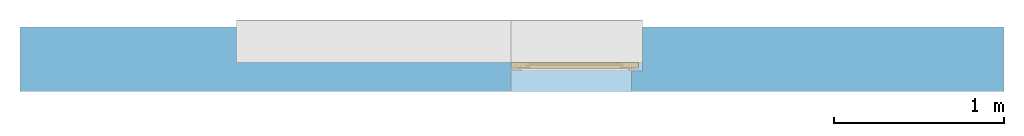
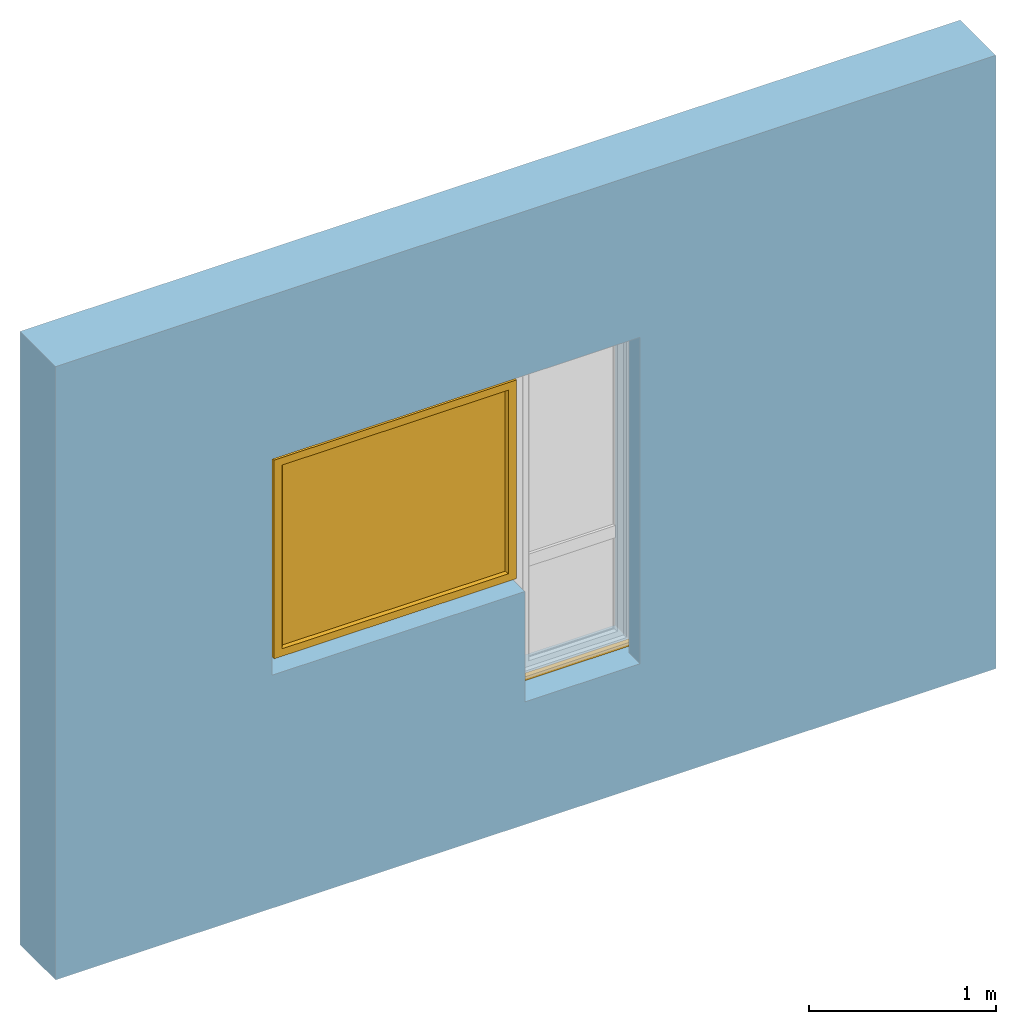
# One storey, part 2 of 4: 1 window, 1 opening, plus 1 element that does not belong to this part.
"""IFC2X3 building model written with IfcOpenShell, lengths in millimetres."""

from ifc_helpers import new_model, entity, si_unit, converted_unit, derived_unit, direction, frame, frame_2d, origin, place, context, subcontext, project, spatial, rectangle, extrude, faceted_brep, source, transform, mapped, material, material_list, layer, layer_set, layer_usage, type_object, type_shapes, element, fill, save


model = new_model("IFC2X3")

# Units and contexts
model_context = context("Model", 3, precision=0.01, world=origin(), true_north=direction((6.12303176911189e-17, 1.0)))
context_of_model = context(None, 3, precision=0.01, world=origin(), true_north=direction((6.12303176911189e-17, 1.0)))
body_context = subcontext(model_context, "Body", "Model", "MODEL_VIEW")
ifc_project = project(units=[si_unit("LENGTHUNIT", "METRE", prefix="MILLI"), si_unit("AREAUNIT", "SQUARE_METRE"), si_unit("VOLUMEUNIT", "CUBIC_METRE"), converted_unit("PLANEANGLEUNIT", "DEGREE", entity("IfcRatioMeasure", 0.0174532925199433), si_unit("PLANEANGLEUNIT", "RADIAN"), dimensions=[0, 0, 0, 0, 0, 0, 0]), si_unit("MASSUNIT", "GRAM", prefix="KILO"), si_unit("TIMEUNIT", "SECOND"), si_unit("FREQUENCYUNIT", "HERTZ"), si_unit("THERMODYNAMICTEMPERATUREUNIT", "DEGREE_CELSIUS"), derived_unit("THERMALTRANSMITTANCEUNIT", [(si_unit("MASSUNIT", "GRAM", prefix="KILO"), 1), (si_unit("THERMODYNAMICTEMPERATUREUNIT", "KELVIN"), -1), (si_unit("TIMEUNIT", "SECOND"), -3)]), derived_unit("VOLUMETRICFLOWRATEUNIT", [(si_unit("LENGTHUNIT", "METRE"), 3), (si_unit("TIMEUNIT", "SECOND"), -1)]), si_unit("ELECTRICCURRENTUNIT", "AMPERE"), si_unit("ELECTRICVOLTAGEUNIT", "VOLT"), si_unit("POWERUNIT", "WATT"), si_unit("FORCEUNIT", "NEWTON", prefix="KILO"), si_unit("ILLUMINANCEUNIT", "LUX"), si_unit("LUMINOUSFLUXUNIT", "LUMEN"), si_unit("LUMINOUSINTENSITYUNIT", "CANDELA"), si_unit("PRESSUREUNIT", "PASCAL")], contexts=[model_context, context_of_model])

# Site, building, storey
site_placement = place(None, origin())
site = spatial("IfcSite", under=ifc_project, at=site_placement, CompositionType="ELEMENT")
building_placement = place(site_placement, origin())
building = spatial("IfcBuilding", under=site, at=building_placement, CompositionType="ELEMENT")
storey_placement = place(building_placement, origin())
storey = spatial("IfcBuildingStorey", under=building, at=storey_placement, CompositionType="ELEMENT", Elevation=0.0)

# Wall, opening, window
ifc_material_1 = material()
ifc_layer = layer(ifc_material_1, 380.0)
ifc_layer_set = layer_set([ifc_layer])
ifc_layer_usage = layer_usage(ifc_layer_set, "AXIS2", "NEGATIVE", 190.0)
wall_type = type_object("IfcWallType", PredefinedType="STANDARD", material=ifc_layer_set)
wall_placement = place(storey_placement, frame((-18279.8270290102, 12543.5585138251, 0.0)))
wall = element("IfcWallStandardCase", 1, at=wall_placement, inside=storey, type_object=wall_type, material=ifc_layer_usage, context=body_context, shape_type="SweptSolid", body=[
    extrude(rectangle(XDim=5800.0, YDim=380.0, at=frame_2d((2900.0, 0.0), x_axis=(-1.0, 0.0))), origin(), (0.0, 0.0, 1.0), 4000.0),
])
opening_placement = place(wall_placement, frame((1270.4425727851, -570.0, 800.0)))
opening = element("IfcOpeningElement", 2, at=opening_placement, cuts=wall, ObjectType="Opening", context=body_context, shape_type="Brep", body=[
    faceted_brep([(2400.0, 1490.0, 2195.0), (2400.0, 1490.0, 0.0), (1625.0, 1490.0, 0.0), (1625.0, 1490.0, 720.0), (0.0, 1490.0, 720.0), (0.0, 1490.0, 2170.0), (0.0, 1490.0, 2195.0), (1330.0, 1490.0, 2195.0), (2400.0, 500.0, 2195.0), (1330.0, 500.0, 2195.0), (0.0, 500.0, 2195.0), (0.0, 500.0, 2170.0), (0.0, 500.0, 720.0), (65.0, 500.0, 720.0), (65.0, 500.0, 2130.0), (1715.0, 500.0, 2130.0), (2335.0, 500.0, 2130.0), (2335.0, 500.0, 0.0), (2400.0, 500.0, 0.0), (1625.0, 0.0, 0.0), (1625.0, 0.0, 720.0), (2335.0, 0.0, 0.0), (65.0, 0.0, 720.0), (2335.0, 0.0, 2130.0), (1715.0, 0.0, 2130.0), (65.0, 0.0, 2130.0)], [[[0, 1, 2, 3, 4, 5, 6, 7]], [[8, 9, 10, 11, 12, 13, 14, 15, 16, 17, 18]], [[7, 9, 8, 0]], [[2, 19, 20, 3]], [[1, 18, 17, 21, 19, 2]], [[0, 8, 18, 1]], [[6, 10, 9, 7]], [[5, 11, 10, 6]], [[4, 12, 11, 5]], [[20, 22, 13, 12, 4, 3]], [[23, 24, 25, 22, 20, 19, 21]], [[23, 16, 15, 24]], [[21, 17, 16, 23]], [[24, 15, 14, 25]], [[25, 14, 13, 22]]]),
])
ifc_material_2 = material()
ifc_material_3 = material()
ifc_material_4 = material()
ifc_material_5 = material()
ifc_material_list_1 = material_list([ifc_material_2, ifc_material_3, ifc_material_4, ifc_material_5])
ifc_material_list_2 = material_list([ifc_material_2, ifc_material_3, ifc_material_4, ifc_material_5])
window_style = type_object("IfcWindowStyle", ConstructionType="NOTDEFINED", OperationType="NOTDEFINED", ParameterTakesPrecedence=False, Sizeable=False, material=ifc_material_list_2)
shared_shape = source(origin(), body_context, "Body", "Brep", [
    faceted_brep([(2316.0, 1030.0, 1488.0), (2316.0, 1030.0, 1452.0), (2316.0, 1038.0, 1452.0), (2316.0, 1038.0, 1488.0), (2315.15676402479, 1038.0, 1492.78534851355), (2315.57778161414, 1030.0, 1490.39432433825), (2310.86155337324, 1030.0, 1498.56228263264), (2309.00202746121, 1038.0, 1500.12318487169), (2308.99898619598, 1030.0, 1500.12494091652), (2293.13844662676, 1038.0, 1498.56228263264), (2294.99797253879, 1030.0, 1500.12318487169), (2295.00101380402, 1038.0, 1500.12494091652), (2312.7263777273, 1038.0, 1496.99693396951), (2312.7241205505, 1030.0, 1496.99962434876), (2313.93984188939, 1030.0, 1494.89413651262), (2304.432995843, 1038.0, 1501.78696961731), (2304.42953736881, 1030.0, 1501.78757948932), (2306.7142617824, 1030.0, 1500.95626020292), (2310.86420259425, 1038.0, 1498.5600594206), (2315.15556322829, 1030.0, 1492.78864867648), (2313.94157087605, 1038.0, 1494.89114124153), (2306.7175116521, 1038.0, 1500.9550772445), (2299.57046263119, 1038.0, 1501.78757948932), (2299.567004157, 1030.0, 1501.78696961731), (2301.9982707629, 1030.0, 1501.78727455331), (2297.2824883479, 1030.0, 1500.9550772445), (2297.2857382176, 1038.0, 1500.95626020292), (2290.05842912395, 1030.0, 1494.89114124153), (2288.84443677171, 1038.0, 1492.78864867648), (2288.84323597521, 1030.0, 1492.78534851355), (2291.2758794495, 1038.0, 1496.99962434876), (2291.2736222727, 1030.0, 1496.99693396951), (2293.13579740575, 1030.0, 1498.5600594206), (2302.0017292371, 1038.0, 1501.78727455331), (2288.0, 1030.0, 1488.0), (2288.42221838586, 1038.0, 1490.39432433825), (2288.0, 1038.0, 1488.0), (2290.06015811061, 1038.0, 1494.89413651262), (2288.0, 1030.0, 1452.0), (2288.0, 1038.0, 1452.0), (2288.84323597521, 1030.0, 1447.21465148647), (2288.84323597521, 1038.0, 1447.21465148647), (2294.99797253879, 1030.0, 1439.87681512833), (2293.13579740575, 1030.0, 1441.43994057942), (2291.2736222727, 1030.0, 1443.00306603051), (2291.2736222727, 1038.0, 1443.00306603051), (2293.13579740575, 1038.0, 1441.43994057942), (2294.99797253879, 1038.0, 1439.87681512833), (2315.57778161414, 1030.0, 1449.60567566177), (2315.15556322829, 1030.0, 1447.21135132354), (2315.15556322829, 1038.0, 1447.21135132354), (2315.56908263974, 1038.0, 1449.55634534639), (2290.05842912395, 1038.0, 1445.10885875849), (2290.05842912395, 1030.0, 1445.10885875849), (2297.2824883479, 1038.0, 1439.04492275552), (2299.567004157, 1038.0, 1438.21303038271), (2299.567004157, 1030.0, 1438.21303038271), (2297.2824883479, 1030.0, 1439.04492275552), (2304.42953736881, 1030.0, 1438.21242051071), (2301.9982707629, 1030.0, 1438.21272544671), (2301.9982707629, 1038.0, 1438.21272544671), (2304.42953736881, 1038.0, 1438.21242051071), (2306.7142617824, 1038.0, 1439.04373979711), (2308.99898619598, 1038.0, 1439.87505908351), (2308.99898619598, 1030.0, 1439.87505908351), (2306.7142617824, 1030.0, 1439.04373979711), (2310.86155337324, 1038.0, 1441.43771736738), (2312.7241205505, 1038.0, 1443.00037565126), (2312.7241205505, 1030.0, 1443.00037565126), (2310.86155337324, 1030.0, 1441.43771736738), (2313.93984188939, 1038.0, 1445.1058634874), (2313.93984188939, 1030.0, 1445.1058634874), (2292.63603896932, 1028.0, 1494.3639610307), (2291.75735931288, 1028.0, 1492.24264068714), (2290.87867965644, 1028.0, 1490.12132034358), (2290.0, 1028.0, 1488.0), (2290.0, 1028.0, 1452.0), (2290.87867965644, 1028.0, 1449.87867965644), (2291.75735931288, 1028.0, 1447.75735931288), (2292.63603896932, 1028.0, 1445.63603896932), (2293.51471862576, 1028.0, 1443.51471862576), (2295.63603896932, 1028.0, 1442.63603896932), (2297.75735931288, 1028.0, 1441.75735931288), (2299.87867965644, 1028.0, 1440.87867965644), (2302.0, 1028.0, 1440.0), (2304.12132034356, 1028.0, 1440.87867965644), (2306.24264068712, 1028.0, 1441.75735931288), (2308.36396103068, 1028.0, 1442.63603896932), (2310.48528137424, 1028.0, 1443.51471862576), (2311.36396103068, 1028.0, 1445.63603896932), (2312.24264068712, 1028.0, 1447.75735931288), (2313.12132034356, 1028.0, 1449.87867965644), (2314.0, 1028.0, 1452.0), (2314.0, 1028.0, 1488.0), (2313.12132034356, 1028.0, 1490.12132034358), (2312.24264068712, 1028.0, 1492.24264068714), (2311.36396103068, 1028.0, 1494.3639610307), (2310.48528137424, 1028.0, 1496.48528137426), (2308.36396103068, 1028.0, 1497.3639610307), (2306.24264068712, 1028.0, 1498.24264068714), (2304.12132034356, 1028.0, 1499.12132034358), (2302.0, 1028.0, 1500.0), (2299.87867965644, 1028.0, 1499.12132034358), (2297.75735931288, 1028.0, 1498.24264068714), (2295.63603896932, 1028.0, 1497.3639610307), (2293.51471862576, 1028.0, 1496.48528137426), (2290.0, 1040.0, 1488.0), (2290.87867965644, 1040.0, 1490.12132034358), (2291.75735931288, 1040.0, 1492.24264068714), (2292.63603896932, 1040.0, 1494.3639610307), (2293.51471862576, 1040.0, 1496.48528137426), (2295.63603896932, 1040.0, 1497.3639610307), (2297.75735931288, 1040.0, 1498.24264068714), (2299.87867965644, 1040.0, 1499.12132034358), (2302.0, 1040.0, 1500.0), (2304.12132034356, 1040.0, 1499.12132034358), (2306.24264068712, 1040.0, 1498.24264068714), (2308.36396103068, 1040.0, 1497.3639610307), (2310.48528137424, 1040.0, 1496.48528137426), (2311.36396103068, 1040.0, 1494.3639610307), (2312.24264068712, 1040.0, 1492.24264068714), (2313.12132034356, 1040.0, 1490.12132034358), (2314.0, 1040.0, 1488.0), (2314.0, 1040.0, 1452.0), (2313.12132034356, 1040.0, 1449.87867965644), (2312.24264068712, 1040.0, 1447.75735931288), (2311.36396103068, 1040.0, 1445.63603896932), (2310.48528137424, 1040.0, 1443.51471862576), (2308.36396103068, 1040.0, 1442.63603896932), (2306.24264068712, 1040.0, 1441.75735931288), (2304.12132034356, 1040.0, 1440.87867965644), (2302.0, 1040.0, 1440.0), (2299.87867965644, 1040.0, 1440.87867965644), (2297.75735931288, 1040.0, 1441.75735931288), (2295.63603896932, 1040.0, 1442.63603896932), (2293.51471862576, 1040.0, 1443.51471862576), (2292.63603896932, 1040.0, 1445.63603896932), (2291.75735931288, 1040.0, 1447.75735931288), (2290.87867965644, 1040.0, 1449.87867965644), (2290.0, 1040.0, 1452.0)], [[[0, 1, 2, 3]], [[4, 5, 3]], [[6, 7, 8]], [[9, 10, 11]], [[12, 13, 14]], [[15, 16, 17]], [[7, 6, 18]], [[5, 0, 3]], [[18, 6, 13]], [[14, 19, 20]], [[4, 19, 5]], [[15, 17, 21]], [[8, 21, 17]], [[12, 14, 20]], [[22, 23, 24]], [[25, 11, 10]], [[26, 23, 22]], [[27, 28, 29]], [[21, 8, 7]], [[20, 19, 4]], [[30, 31, 32]], [[33, 16, 15]], [[34, 35, 36]], [[11, 25, 26]], [[23, 26, 25]], [[37, 27, 31]], [[32, 10, 9]], [[29, 28, 35]], [[30, 32, 9]], [[34, 29, 35]], [[28, 27, 37]], [[18, 13, 12]], [[33, 24, 16]], [[37, 31, 30]], [[22, 24, 33]], [[38, 34, 36, 39]], [[40, 38, 39, 41]], [[42, 43, 44, 45, 46, 47]], [[2, 1, 48, 49, 50, 51]], [[41, 52, 45, 44, 53, 40]], [[47, 54, 55, 56, 57, 42]], [[58, 59, 56, 55, 60, 61]], [[61, 62, 63, 64, 65, 58]], [[66, 67, 68, 69, 64, 63]], [[67, 70, 50, 49, 71, 68]], [[72, 73, 74, 75, 76, 77, 78, 79, 80, 81, 82, 83, 84, 85, 86, 87, 88, 89, 90, 91, 92, 93, 94, 95, 96, 97, 98, 99, 100, 101, 102, 103, 104, 105]], [[92, 48, 1]], [[48, 92, 91]], [[71, 49, 90]], [[44, 79, 53]], [[90, 49, 91]], [[78, 40, 53]], [[88, 68, 89]], [[88, 69, 68]], [[69, 87, 64]], [[89, 68, 71]], [[82, 57, 83]], [[91, 49, 48]], [[65, 85, 58]], [[82, 42, 57]], [[56, 84, 83]], [[65, 64, 86]], [[56, 83, 57]], [[76, 38, 77]], [[58, 84, 56, 59]], [[80, 44, 43]], [[85, 65, 86]], [[40, 77, 38]], [[82, 81, 42]], [[40, 78, 77]], [[43, 81, 80]], [[71, 90, 89]], [[87, 69, 88]], [[79, 44, 80]], [[79, 78, 53]], [[87, 86, 64]], [[85, 84, 58]], [[43, 42, 81]], [[92, 1, 0, 93]], [[72, 31, 27]], [[34, 74, 29]], [[27, 29, 73]], [[13, 96, 14]], [[74, 73, 29]], [[95, 19, 14]], [[104, 32, 105]], [[105, 32, 31]], [[32, 104, 10]], [[105, 31, 72]], [[99, 17, 100]], [[74, 34, 75]], [[25, 102, 23]], [[99, 8, 17]], [[16, 101, 100]], [[25, 10, 103]], [[16, 100, 17]], [[5, 93, 0]], [[99, 98, 8]], [[97, 13, 6]], [[93, 5, 94]], [[102, 25, 103]], [[94, 5, 19]], [[24, 23, 101, 16]], [[27, 73, 72]], [[96, 13, 97]], [[6, 98, 97]], [[96, 95, 14]], [[104, 103, 10]], [[102, 101, 23]], [[6, 8, 98]], [[94, 19, 95]], [[75, 34, 38, 76]], [[106, 107, 108, 109, 110, 111, 112, 113, 114, 115, 116, 117, 118, 119, 120, 121, 122, 123, 124, 125, 126, 127, 128, 129, 130, 131, 132, 133, 134, 135, 136, 137, 138, 139]], [[136, 45, 52]], [[39, 138, 41]], [[52, 41, 137]], [[67, 126, 70]], [[138, 137, 41]], [[125, 50, 70]], [[134, 46, 135]], [[135, 46, 45]], [[46, 134, 47]], [[135, 45, 136]], [[129, 62, 130]], [[138, 39, 139]], [[54, 132, 55]], [[129, 63, 62]], [[61, 131, 130]], [[54, 47, 133]], [[61, 130, 62]], [[51, 123, 2]], [[129, 128, 63]], [[127, 67, 66]], [[123, 51, 124]], [[132, 54, 133]], [[124, 51, 50]], [[60, 55, 131, 61]], [[52, 137, 136]], [[126, 67, 127]], [[66, 128, 127]], [[126, 125, 70]], [[134, 133, 47]], [[132, 131, 55]], [[66, 63, 128]], [[124, 50, 125]], [[122, 3, 2, 123]], [[119, 12, 20]], [[3, 121, 4]], [[20, 4, 120]], [[30, 109, 37]], [[121, 120, 4]], [[108, 28, 37]], [[117, 18, 118]], [[118, 18, 12]], [[18, 117, 7]], [[118, 12, 119]], [[112, 26, 113]], [[121, 3, 122]], [[21, 115, 15]], [[112, 11, 26]], [[22, 114, 113]], [[21, 7, 116]], [[22, 113, 26]], [[35, 106, 36]], [[112, 111, 11]], [[110, 30, 9]], [[106, 35, 107]], [[115, 21, 116]], [[107, 35, 28]], [[33, 15, 114, 22]], [[20, 120, 119]], [[109, 30, 110]], [[9, 111, 110]], [[109, 108, 37]], [[117, 116, 7]], [[115, 114, 15]], [[9, 11, 111]], [[107, 28, 108]], [[139, 39, 36, 106]]]),
    faceted_brep([(2296.70849737789, 979.723224744612, 1410.52114796617), (2307.29150262214, 979.723224744611, 1410.52114796617), (2307.29150262214, 984.162114765246, 1452.66882878318), (2296.70849737789, 984.162114765247, 1452.66882878318), (2309.48331477356, 988.551651869357, 1410.52114796617), (2309.48331477356, 992.796844327483, 1450.82965209673), (2302.0, 993.723224744612, 1410.52114796617), (2302.0, 997.854951797618, 1449.75228733741), (2294.51668522647, 988.551651869359, 1410.52114796617), (2294.51668522647, 992.796844327484, 1450.82965209673), (2296.70849737789, 984.162114765246, 1368.37346714915), (2307.29150262214, 984.162114765245, 1368.37346714915), (2309.48331477356, 992.796844327482, 1370.2126438356), (2302.0, 997.854951797618, 1371.29000859492), (2294.51668522647, 992.796844327484, 1370.2126438356)], [[[0, 1, 2, 3]], [[1, 4, 5, 2]], [[4, 6, 7, 5]], [[6, 8, 9, 7]], [[8, 0, 3, 9]], [[10, 11, 1, 0]], [[11, 12, 4, 1]], [[12, 13, 6, 4]], [[13, 14, 8, 6]], [[14, 10, 0, 8]], [[3, 2, 5, 7, 9]], [[14, 13, 12, 11, 10]]]),
    faceted_brep([(2292.05108068303, 1028.0, 1470.94591729901), (2292.6116955587, 1028.0, 1473.43924096907), (2293.78926206305, 1028.0, 1475.70333478471), (2295.50517385398, 1028.0, 1477.59726390535), (2297.64110105648, 1028.0, 1479.0), (2302.0, 1028.0, 1479.0), (2306.35889894356, 1028.0, 1479.0), (2308.49482614605, 1028.0, 1477.59726390535), (2310.21073793698, 1028.0, 1475.70333478471), (2311.38830444134, 1028.0, 1473.43924096907), (2311.948919317, 1028.0, 1470.94591729901), (2311.86909546584, 1028.0, 1468.3919203214), (2311.13720137139, 1028.0, 1465.94604186494), (2309.80945551189, 1028.0, 1463.7614130413), (2307.97703479258, 1028.0, 1461.98307257928), (2305.74800577773, 1028.0, 1460.73512735946), (2303.27629940962, 1028.0, 1460.08403873227), (2300.72370059042, 1028.0, 1460.08403873227), (2298.25199422231, 1028.0, 1460.73512735946), (2296.02296520745, 1028.0, 1461.98307257928), (2294.19054448814, 1028.0, 1463.7614130413), (2292.86279862864, 1028.0, 1465.94604186494), (2292.13090453419, 1028.0, 1468.3919203214), (2295.36991581395, 985.428800128993, 1451.81582813483), (2294.45534262368, 986.933218860171, 1450.80273507336), (2294.03032959918, 988.579532805234, 1449.69408812541), (2294.11827066873, 990.263398076606, 1448.56015367782), (2294.7119819839, 991.873838872343, 1447.47566412563), (2295.77997796969, 993.307181915701, 1446.51043425854), (2297.2448781787, 994.474223513816, 1445.72453488026), (2299.01896983583, 995.293497882215, 1445.17282599704), (2300.98499562504, 995.719017712972, 1444.88627599662), (2303.01500437499, 995.719017712972, 1444.88627599662), (2304.9810301642, 995.293497882215, 1445.17282599704), (2306.75512182133, 994.474223513816, 1445.72453488026), (2308.22002203034, 993.307181915701, 1446.51043425854), (2309.28801801613, 991.873838872343, 1447.47566412563), (2309.88172933131, 990.263398076606, 1448.56015367782), (2309.96967040085, 988.579532805233, 1449.69408812541), (2309.54465737635, 986.933218860171, 1450.80273507336), (2308.63008418608, 985.428800128993, 1451.81582813483), (2307.29150262214, 984.16133280708, 1452.6693553629), (2303.79310555172, 984.16133280708, 1452.6693553629), (2300.2508014648, 984.16133280708, 1452.6693553629), (2296.70849737789, 984.16133280708, 1452.6693553629), (2304.52949888047, 998.583676958967, 1468.53479166182), (2302.0, 1001.40749625602, 1470.46960324719), (2302.02195286218, 991.069044221466, 1461.86725150298), (2307.17259060864, 988.432156174774, 1457.7486255059), (2304.75377578685, 990.997000236885, 1461.79007956711), (2299.62092495289, 997.432874221653, 1467.66721198755), (2299.76284265702, 1005.82183838693, 1473.00337884316), (2297.01936527075, 995.326410429836, 1465.9479296637), (2299.15805318919, 990.078190113558, 1460.7785343575), (2300.96832520456, 1014.05926083179, 1476.41174131507), (2297.33023316361, 1010.43252257805, 1475.10298096761), (2304.09205911857, 1018.08338546997, 1477.54270145077), (2306.98063472928, 995.326410429835, 1465.9479296637), (2306.66976683642, 1010.43252257805, 1475.10298096761), (2310.33445262988, 995.924208850621, 1455.92276589621), (2310.86792617061, 1008.48015750033, 1468.07942490609), (2311.45909914595, 1017.75942703354, 1470.08550854293), (2305.91403231325, 999.739374449793, 1450.68801313961), (2307.61971635533, 1004.55574499169, 1455.78506579303), (2295.02520991073, 1001.74472638059, 1455.70424775686), (2292.98228348089, 1009.89849311155, 1468.22389640409), (2295.18111717899, 1012.97756270999, 1460.9239931882), (2308.84403415027, 1015.58259477426, 1461.67364545901), (2310.7354074063, 1001.45564404689, 1462.17506192797), (2292.69314957983, 1018.88103613784, 1466.84627828438), (2299.47019846674, 1020.31531244094, 1459.97313305256)], [[[0, 1, 2, 3, 4, 5, 6, 7, 8, 9, 10, 11, 12, 13, 14, 15, 16, 17, 18, 19, 20, 21, 22]], [[23, 24, 25, 26, 27, 28, 29, 30, 31, 32, 33, 34, 35, 36, 37, 38, 39, 40, 41, 42, 43, 44]], [[45, 46, 47]], [[42, 41, 48]], [[49, 45, 47]], [[50, 46, 51]], [[50, 51, 52]], [[43, 47, 53]], [[53, 50, 52]], [[54, 4, 55]], [[44, 43, 53]], [[56, 6, 5]], [[48, 49, 42]], [[42, 47, 43]], [[49, 48, 57]], [[5, 54, 56]], [[49, 57, 45]], [[42, 49, 47]], [[57, 58, 45]], [[58, 46, 45]], [[50, 47, 46]], [[44, 53, 52]], [[47, 50, 53]], [[46, 54, 51]], [[56, 46, 58]], [[4, 54, 5]], [[54, 55, 51]], [[52, 51, 55]], [[46, 56, 54]], [[6, 56, 58]], [[40, 59, 41]], [[39, 38, 59]], [[59, 40, 39]], [[36, 59, 37]], [[60, 61, 58]], [[35, 34, 62]], [[62, 59, 36]], [[59, 62, 63]], [[33, 62, 34]], [[35, 62, 36]], [[38, 37, 59]], [[9, 8, 61]], [[61, 10, 9]], [[64, 65, 66]], [[8, 7, 61]], [[58, 7, 6]], [[58, 61, 7]], [[63, 67, 68]], [[67, 13, 61]], [[52, 55, 65]], [[67, 60, 68]], [[31, 62, 32]], [[59, 68, 57]], [[13, 67, 14]], [[65, 69, 66]], [[10, 61, 11]], [[11, 61, 12]], [[69, 55, 1]], [[16, 70, 17]], [[33, 32, 62]], [[66, 67, 63]], [[69, 70, 66]], [[67, 66, 70]], [[70, 15, 67]], [[29, 64, 30]], [[27, 64, 28]], [[64, 29, 28]], [[65, 64, 52]], [[25, 24, 64]], [[57, 60, 58]], [[64, 24, 52]], [[23, 44, 52]], [[67, 61, 60]], [[23, 52, 24]], [[64, 26, 25]], [[69, 65, 55]], [[63, 64, 66]], [[69, 20, 19]], [[69, 21, 20]], [[61, 13, 12]], [[60, 57, 68]], [[70, 16, 15]], [[17, 70, 18]], [[68, 59, 63]], [[62, 64, 63]], [[19, 18, 70]], [[69, 1, 0]], [[0, 22, 69]], [[1, 55, 2]], [[30, 62, 31]], [[64, 27, 26]], [[3, 2, 55]], [[4, 3, 55]], [[19, 70, 69]], [[15, 14, 67]], [[21, 69, 22]], [[59, 57, 48, 41]], [[64, 62, 30]]]),
    faceted_brep([(2323.0, 1110.0, 2118.0), (2323.0, 1055.0, 2118.0), (2323.0, 1055.0, 822.0), (2323.0, 1110.0, 822.0), (2262.00008196447, 1095.0, 2057.00008196447), (2274.0, 1110.0, 2069.0), (2274.0, 1110.0, 871.0), (2262.00008196447, 1095.0, 882.999918035525), (2290.0, 1053.0, 2085.0), (2290.0, 1095.0, 2085.0), (2290.0, 1095.0, 855.0), (2290.0, 1053.0, 855.0), (2274.0, 1041.0, 2069.0), (2262.0, 1053.0, 2057.0), (2262.0, 1053.0, 883.0), (2274.0, 1041.0, 871.0), (2287.0, 1040.0, 2082.0), (2287.0, 1041.0, 2082.0), (2287.0, 1041.0, 858.0), (2287.0, 1040.0, 858.0), (2343.0, 1042.0, 2138.0), (2341.0, 1040.0, 2136.0), (2341.0, 1040.0, 804.0), (2343.0, 1042.0, 802.0), (2343.0, 1055.0, 2138.0), (2343.0, 1055.0, 802.0), (827.0, 1055.0, 822.0), (827.0, 1110.0, 822.0), (876.0, 1110.0, 871.0), (887.999918035528, 1095.0, 882.999918035525), (860.0, 1095.0, 855.0), (860.0, 1053.0, 855.0), (888.0, 1053.0, 883.0), (876.0, 1041.0, 871.0), (863.0, 1041.0, 858.0), (863.0, 1040.0, 858.0), (809.0, 1040.0, 804.0), (807.0, 1042.0, 802.0), (807.0, 1055.0, 802.0), (827.0, 1055.0, 2118.0), (827.0, 1110.0, 2118.0), (876.0, 1110.0, 2069.0), (887.999918035528, 1095.0, 2057.00008196447), (860.0, 1095.0, 2085.0), (860.0, 1053.0, 2085.0), (888.0, 1053.0, 2057.0), (876.0, 1041.0, 2069.0), (863.0, 1041.0, 2082.0), (863.0, 1040.0, 2082.0), (809.0, 1040.0, 2136.0), (807.0, 1042.0, 2138.0), (807.0, 1055.0, 2138.0)], [[[0, 1, 2, 3]], [[4, 5, 6, 7]], [[8, 9, 10, 11]], [[12, 13, 14, 15]], [[16, 17, 18, 19]], [[20, 21, 22, 23]], [[24, 20, 23, 25]], [[3, 2, 26, 27]], [[7, 6, 28, 29]], [[11, 10, 30, 31]], [[15, 14, 32, 33]], [[19, 18, 34, 35]], [[23, 22, 36, 37]], [[25, 23, 37, 38]], [[27, 26, 39, 40]], [[29, 28, 41, 42]], [[31, 30, 43, 44]], [[33, 32, 45, 46]], [[35, 34, 47, 48]], [[37, 36, 49, 50]], [[38, 37, 50, 51]], [[40, 39, 1, 0]], [[3, 27, 40, 0], [5, 41, 28, 6]], [[42, 41, 5, 4]], [[7, 29, 42, 4], [9, 43, 30, 10]], [[44, 43, 9, 8]], [[11, 31, 44, 8], [13, 45, 32, 14]], [[46, 45, 13, 12]], [[15, 33, 46, 12], [17, 47, 34, 18]], [[48, 47, 17, 16]], [[19, 35, 48, 16], [21, 49, 36, 22]], [[50, 49, 21, 20]], [[51, 50, 20, 24]], [[1, 39, 26, 2], [25, 38, 51, 24]]], outer=[[True], [True], [True], [True], [True], [True], [True], [True], [True], [True], [True], [True], [True], [True], [True], [True], [True], [True], [True], [True], [True], [True], [True, False], [True], [False, True], [True], [True, False], [True], [False, True], [True], [False, True], [True], [True], [False, True]]),
    faceted_brep([(872.0, 1053.0, 2073.0), (872.0, 1053.0, 867.0), (2278.0, 1053.0, 867.0), (2278.0, 1053.0, 2073.0), (872.0, 1095.0, 2073.0), (2278.0, 1095.0, 2073.0), (2278.0, 1095.0, 867.0), (872.0, 1095.0, 867.0)], [[[0, 1, 2, 3]], [[4, 5, 6, 7]], [[1, 0, 4, 7]], [[2, 1, 7, 6]], [[3, 2, 6, 5]], [[0, 3, 5, 4]]]),
    faceted_brep([(860.0, 1058.0, 855.0), (860.0, 1090.0, 855.0), (2290.0, 1090.0, 855.0), (2290.0, 1058.0, 855.0), (888.0, 1063.0, 883.0), (888.0, 1058.0, 883.0), (2262.0, 1058.0, 883.0), (2262.0, 1063.0, 883.0), (872.0, 1085.0, 867.0), (872.0, 1063.0, 867.0), (2278.0, 1063.0, 867.0), (2278.0, 1085.0, 867.0), (888.0, 1090.0, 883.0), (888.0, 1085.0, 883.0), (2262.0, 1085.0, 883.0), (2262.0, 1090.0, 883.0), (2290.0, 1090.0, 2085.0), (2290.0, 1058.0, 2085.0), (2262.0, 1058.0, 2057.0), (2262.0, 1063.0, 2057.0), (2278.0, 1063.0, 2073.0), (2278.0, 1085.0, 2073.0), (2262.0, 1085.0, 2057.0), (2262.0, 1090.0, 2057.0), (860.0, 1090.0, 2085.0), (860.0, 1058.0, 2085.0), (888.0, 1058.0, 2057.0), (888.0, 1063.0, 2057.0), (872.0, 1063.0, 2073.0), (872.0, 1085.0, 2073.0), (888.0, 1085.0, 2057.0), (888.0, 1090.0, 2057.0)], [[[0, 1, 2, 3]], [[4, 5, 6, 7]], [[8, 9, 10, 11]], [[12, 13, 14, 15]], [[3, 2, 16, 17]], [[7, 6, 18, 19]], [[11, 10, 20, 21]], [[15, 14, 22, 23]], [[17, 16, 24, 25]], [[19, 18, 26, 27]], [[21, 20, 28, 29]], [[23, 22, 30, 31]], [[15, 23, 31, 12], [1, 24, 16, 2]], [[25, 24, 1, 0]], [[3, 17, 25, 0], [5, 26, 18, 6]], [[27, 26, 5, 4]], [[7, 19, 27, 4], [9, 28, 20, 10]], [[29, 28, 9, 8]], [[11, 21, 29, 8], [13, 30, 22, 14]], [[31, 30, 13, 12]]], outer=[[True], [True], [True], [True], [True], [True], [True], [True], [True], [True], [True], [True], [False, True], [True], [True, False], [True], [False, True], [True], [True, False], [True]]),
    faceted_brep([(2375.0, 990.0, 2170.0), (2375.0, 920.0, 2170.0), (2375.0, 920.0, 770.0), (2375.0, 990.0, 770.0), (775.0, 920.0, 770.0), (775.0, 990.0, 770.0), (775.0, 920.0, 2170.0), (815.0, 920.0, 810.0), (815.0, 920.0, 2130.0), (2335.0, 920.0, 2130.0), (2335.0, 920.0, 810.0), (775.0, 990.0, 2170.0), (2322.0, 990.0, 823.0), (2322.0, 990.0, 2117.0), (828.0, 990.0, 2117.0), (828.0, 990.0, 823.0), (2335.0, 975.0, 2130.0), (2335.0, 975.0, 810.0), (815.0, 975.0, 810.0), (815.0, 975.0, 2130.0), (840.0, 975.0, 835.0), (840.0, 975.0, 2105.0), (2310.0, 975.0, 2105.0), (2310.0, 975.0, 835.0)], [[[0, 1, 2, 3]], [[3, 2, 4, 5]], [[2, 1, 6, 4], [7, 8, 9, 10]], [[5, 4, 6, 11]], [[5, 11, 0, 3], [12, 13, 14, 15]], [[9, 16, 17, 10]], [[10, 17, 18, 7]], [[17, 16, 19, 18], [20, 21, 22, 23]], [[7, 18, 19, 8]], [[22, 13, 12, 23]], [[20, 15, 14, 21]], [[23, 12, 15, 20]], [[11, 6, 1, 0]], [[8, 19, 16, 9]], [[21, 14, 13, 22]]]),
    faceted_brep([(775.0, 940.0, 50.0), (25.0, 940.0, 50.0), (25.0, 940.0, 25.0), (775.0, 940.0, 25.0), (775.0, 970.0, 50.0), (775.0, 970.0, 25.0), (25.0, 970.0, 25.0), (25.0, 970.0, 50.0)], [[[0, 1, 2, 3]], [[4, 5, 6, 7]], [[5, 4, 0, 3]], [[6, 5, 3, 2]], [[7, 6, 2, 1]], [[4, 7, 1, 0]]]),
    faceted_brep([(2375.0, 940.0, 770.0), (775.0, 940.0, 770.0), (775.0, 940.0, 745.0), (2375.0, 940.0, 745.0), (2375.0, 970.0, 770.0), (2375.0, 970.0, 745.0), (775.0, 970.0, 745.0), (775.0, 970.0, 770.0)], [[[0, 1, 2, 3]], [[4, 5, 6, 7]], [[4, 7, 1, 0]], [[7, 6, 2, 1]], [[6, 5, 3, 2]], [[5, 4, 0, 3]]]),
])
type_shapes(window_style, [shared_shape])
window_placement = place(opening_placement, frame((2400.0, 1490.0, 0.0), z_axis=(0.0, 0.0, 1.0), x_axis=(-1.0, 0.0, 0.0)))
window = element("IfcWindow", 3, at=window_placement, inside=storey, type_object=window_style, material=ifc_material_list_1, OverallHeight=2194.99999999994, OverallWidth=2400.0, context=body_context, shape_type="MappedRepresentation", body=[
    mapped(shared_shape, transform((0.0, 0.0, 0.0), scale=1.0)),
])
fill(opening, window)

save(model, "model.ifc")
